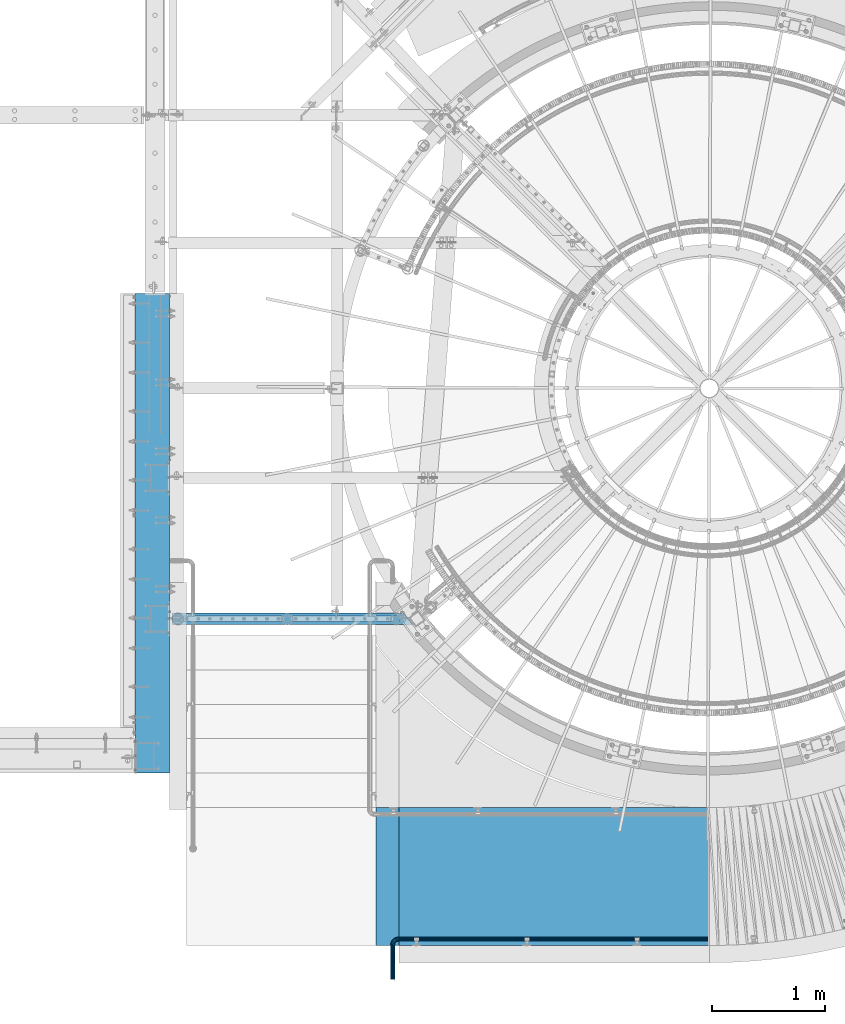
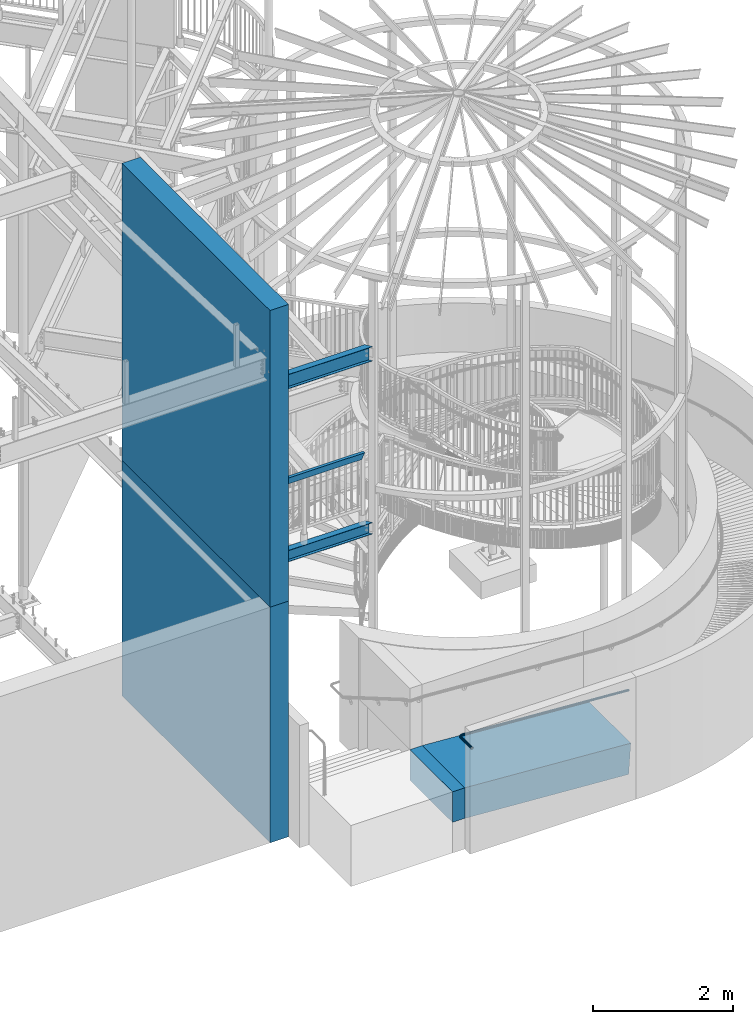
# One storey, part 334 of 975: 8 beams.
"""IFC2X3 building model written with IfcOpenShell, lengths in millimetres."""

from ifc_helpers import new_model, si_unit, frame, origin_with_axes, place, context, subcontext, project, spatial, faceted_brep, material, type_object, element, save


model = new_model("IFC2X3")

# Units and contexts
model_context = context("Model", 3, precision=1e-05, world=origin_with_axes())
body_context = subcontext(model_context, "Body", "Model", "MODEL_VIEW")
ifc_project = project(units=[si_unit("LENGTHUNIT", "METRE", prefix="MILLI"), si_unit("AREAUNIT", "SQUARE_METRE"), si_unit("VOLUMEUNIT", "CUBIC_METRE"), si_unit("MASSUNIT", "GRAM", prefix="KILO"), si_unit("TIMEUNIT", "SECOND"), si_unit("PLANEANGLEUNIT", "RADIAN"), si_unit("SOLIDANGLEUNIT", "STERADIAN"), si_unit("THERMODYNAMICTEMPERATUREUNIT", "DEGREE_CELSIUS"), si_unit("LUMINOUSINTENSITYUNIT", "LUMEN")], contexts=[model_context])

# Site, building, storey
site_placement = place(None, origin_with_axes())
site = spatial("IfcSite", under=ifc_project, at=site_placement, CompositionType="ELEMENT")
building_placement = place(site_placement, origin_with_axes())
building = spatial("IfcBuilding", under=site, at=building_placement, Name="Undefined", CompositionType="ELEMENT")
storey_placement = place(building_placement, origin_with_axes())
storey = spatial("IfcBuildingStorey", under=building, at=storey_placement, Name="Undefined", CompositionType="ELEMENT", Elevation=0.0)

# Beams
ifc_material_1 = material()
beam_type_1 = type_object("IfcBeamType", PredefinedType="NOTDEFINED")
beam_1_placement = place(storey_placement, frame((34733.2743603004, -1466.84998513613, 1780.94769340117), z_axis=(0.0, -1.0, 0.0), x_axis=(-0.997824495007209, 0.0, 0.0659263010005001)))
element("IfcBeam", 1, at=beam_1_placement, inside=storey, type_object=beam_type_1, material=ifc_material_1, Name="HANDRAIL", context=body_context, shape_type="Brep", body=[
    faceted_brep([(-2.63386027654633e-07, -19.0500000000029, 0.0), (-2.28097633225843e-07, -16.4977839420972, -9.52499999999964), (2747.42550358236, -16.4977819359397, -9.52499981342589), (2747.42550358358, -19.0499979938454, 1.86573970495374e-07), (-1.31691194837913e-07, -9.52500000000146, -16.4977839420935), (2747.42550357773, -9.52499799384577, -16.4977837555193), (-3.63797880709171e-12, 3.63797880709171e-12, -19.0500000000002), (2747.42550357094, 2.00615295398165e-06, -19.0499998134258), (1.31687556859106e-07, 9.52500000000509, -16.4977839420935), (2747.4255035638, 9.52500200615304, -16.4977837555193), (2.28097633225843e-07, 16.4977839421044, -9.52499999999964), (2747.42550355823, 16.4977859482465, -9.52499981342589), (2.63382389675826e-07, 19.0500000000138, 0.0), (2747.42550355572, 19.0500020061527, 1.86574197869049e-07), (2.28097633225843e-07, 16.4977839421044, 9.52499999999964), (2747.42550355694, 16.4977859482465, 9.52500018657452), (1.31687556859106e-07, 9.52500000000509, 16.4977839420935), (2747.42550356158, 9.5250020061535, 16.4977841286679), (-3.63797880709171e-12, 3.63797880709171e-12, 19.0500000000002), (2747.42550356837, 2.00615386347636e-06, 19.0500001865744), (-1.31691194837913e-07, -9.52500000000146, 16.4977839420935), (2747.4255035755, -9.52499799384623, 16.4977841286677), (-2.28097633225843e-07, -16.4977839420972, 9.52499999999964), (2747.42550358107, -16.4977819359397, 9.52500018657406), (-2.1246523829177e-07, -15.367000000002, 0.0), (-1.83998054126278e-07, -13.3082123799541, 7.68350000000009), (2747.42550357886, -13.3082103738016, 7.68350018657429), (2747.42550358089, -15.3669979938459, 1.86574425242725e-07), (-1.06232619145885e-07, -7.68349999999919, 13.3082123799559), (2747.42550357437, -7.68349799384578, 13.3082125665296), (-3.63797880709171e-12, 3.63797880709171e-12, 15.3670000000002), (2747.42550356861, 2.00615386347636e-06, 15.3670001865744), (1.06225343188271e-07, 7.68350000000646, 13.3082123799559), (2747.42550356313, 7.6835020061535, 13.3082125665296), (1.8399441614747e-07, 13.308212379965, 7.68350000000009), (2747.4255035594, 13.3082143861088, 7.68350018657429), (2.12461600312963e-07, 15.3670000000093, 0.0), (2747.42550355841, 15.3670020061527, 1.86574425242725e-07), (1.8399441614747e-07, 13.308212379965, -7.68350000000009), (2747.42550356044, 13.3082143861079, -7.6834998134259), (1.06225343188271e-07, 7.68350000000646, -13.3082123799559), (2747.42550356493, 7.68350200615305, -13.3082121933812), (-3.63797880709171e-12, 3.63797880709171e-12, -15.3670000000002), (2747.42550357069, 2.00615340872901e-06, -15.3669998134258), (-1.06232619145885e-07, -7.68349999999919, -13.3082123799559), (2747.42550357617, -7.68349799384623, -13.3082121933815), (-1.83998054126278e-07, -13.3082123799541, -7.68350000000009), (2747.4255035799, -13.308210373802, -7.68349981342567), (2749.09855348467, -16.4977819347173, -9.52499981331198), (2749.18278450733, -19.0499979925621, 1.86693569048657e-07), (2748.86844838869, -9.52499799279258, -16.4977837554213), (2748.55412569402, 2.00697741092881e-06, -19.0499998133491), (2748.23980791288, 9.5250020067474, -16.4977837554641), (2748.00971624088, 16.497785948673, -9.5249998133861), (2747.92550355573, 19.0500020065178, 1.86608303920366e-07), (2748.00973457838, 16.497785948673, 9.52500018661385), (2748.23983967437, 9.52500200674785, 16.4977841287232), (2748.55416236903, 2.00697786567616e-06, 19.050000186651), (2748.86848015017, -9.52499799279258, 16.4977841287659), (2749.09857182217, -16.4977819347178, 9.52500018668798), (2748.99331578265, -13.3082103726565, 7.6835001866807), (2749.06124734867, -15.3669979926512, 1.86685383596341e-07), (2748.80770850056, -7.68349799283669, 13.3082125666238), (2748.55415882378, 2.00697832042351e-06, 15.3670001866508), (2748.30060518342, 7.68350200679242, 13.3082125665892), (2748.11498707266, 13.3082143866118, 7.6835001866209), (2748.04704071438, 15.367002006607, 1.86616489372682e-07), (2748.11497228041, 13.3082143866118, -7.68349981337883), (2748.30057956249, 7.68350200679151, -13.3082121933219), (2748.55412923927, 2.00697741092881e-06, -15.3669998133491), (2748.80768287963, -7.68349799283669, -13.3082121932873), (2748.99330099039, -13.308210372657, -7.68349981331926), (2750.76796359829, -16.387483031016, -9.52500198382563), (2750.93624235249, -18.9341453696939, -1.98383168026339e-06), (2750.30825404867, -9.42986971660639, -16.4977859259375), (2749.68029250621, 0.0744077046915663, -19.0500019838819), (2749.05234075907, 9.57868577320005, -16.4977859260225), (2748.59265797081, 16.5363008558202, -9.5250019839732), (2748.4244157733, 19.082965609919, -1.98400221051998e-06), (2748.5926945275, 16.5363032712407, 9.52499801599151), (2749.05240407712, 9.57868995683066, 16.4977819581034), (2749.68036561958, 0.0744125355327014, 19.0499980160475), (2750.30831736671, -9.42986553297533, 16.4977819581886), (2750.76800015497, -16.3874806155959, 9.52499801613908), (2750.55771707717, -13.2048484066922, 7.68349801612817), (2750.69343244983, -15.2591579749978, -1.9838482785417e-06), (2750.18690629464, -7.59237224004482, 13.3082103960483), (2749.68035855196, 0.0744120685517373, 15.3669980160544), (2749.1738029077, 7.7411958550656, 13.3082103959794), (2748.80297053767, 13.3536705953561, 7.68349801600925), (2748.66722567595, 15.4079782152226, -1.98398583961534e-06), (2748.80294104861, 13.3536686469165, -7.68350198396251), (2749.17375183115, 7.74119248026955, -13.3082143638824), (2749.68029957383, 0.0744081716734399, -15.3670019838887), (2750.18685521809, -7.59237561484088, -13.3082143638137), (2750.55768758811, -13.2048503551318, -7.68350198384337), (2755.38214503701, -16.082619687113, -9.52501087703058), (2755.55042379118, -18.6292820257891, -2.03573856651929e-05), (2754.92243548739, -9.12500637270387, -16.4977948191422), (2754.29447394492, 0.379271048594546, -19.0500108770866), (2753.66652219779, 9.88354911710258, -16.4977948192275), (2753.20683940953, 16.8411641997232, -9.52501087717792), (2753.03859721201, 19.387828953822, -1.08772071598651e-05), (2753.20687596621, 16.8411666151437, 9.52498912278679), (2753.66658551584, 9.88355330073364, 16.4977730648986), (2754.2945470583, 0.379275879435681, 19.0499891228428), (2754.92249880543, -9.12500218907235, 16.4977730649837), (2755.38218159369, -16.0826172716929, 9.52498912293413), (2755.17189851589, -12.8999850627897, 7.68348912292322), (2755.30761388853, -14.9542946310944, -1.85245348802709e-05), (2754.80108773335, -7.28750889614184, 13.3082015028433), (2754.29453999067, 0.379275412454717, 15.3669891228496), (2753.78798434642, 8.04605919896858, 13.3082015027744), (2753.41715197639, 13.6585339392586, 7.6834891228043), (2753.28140711467, 15.7128415591255, -1.08771905615868e-05), (2753.41712248732, 13.6585319908195, -7.68351087716724), (2753.78793326986, 8.04605582417253, -13.3082232570873), (2754.29448101255, 0.379271515575965, -15.3670108770934), (2754.80103665681, -7.2875122709379, -13.3082232570184), (2755.17186902683, -12.8999870112289, -7.68351087704832), (2771.21427477107, -17.5943535416877, 2.48625571275124), (2768.10906131745, -15.2417425758399, 11.5450802974888), (2765.49936367507, -8.42618490231234, 18.1766022661197), (2764.08444821971, 1.0260963043047, 20.6039106625612), (2764.24344040497, 10.5823699280672, 18.1766101622038), (2765.93373840322, 17.6820401688369, 11.5450939739067), (2768.70242823086, 20.4227561190723, 2.48627150491802), (2771.80764168449, 18.0701451532241, -6.57255307981995), (2774.41733932686, 11.254587479697, -13.2040750484514), (2775.83225478223, 1.80230627307947, -15.6313834448922), (2775.67326259696, -7.75396735068307, -13.2040829445345), (2773.98296459871, -14.8536375914523, -6.57256675623785), (2774.69663348118, 1.72727264276409, -12.1286383478387), (2773.55526834719, 9.35211281610236, -10.1706095747093), (2771.450112249, 14.8499960060813, -4.82118185334707), (2768.94524006308, 16.7477688518652, 2.48626997834185), (2766.71183026878, 14.536924652009, 9.793720103326), (2765.34832321686, 8.8098573244547, 15.1431431618855), (2765.22006952075, 1.10112993461962, 17.101165565507), (2766.36143465474, -6.52371023871865, 15.1431367923781), (2768.46659075292, -12.0215934286975, 9.79370907101543), (2770.97146293885, -13.9193662744806, 2.48625723932696), (2773.20487273314, -11.7085220746244, -4.82119288565696), (2774.56837978507, -5.98145474707007, -10.1706159442167), (2788.58769674432, 19.1788296229693, 1.99586386588931), (2793.13695432239, 12.4914217064702, -3.64525859803371), (2782.83299844192, 21.3563849829693, 9.70177925010557), (2777.414826178, 18.4406135862837, 17.4076937504717), (2773.78497483513, 11.2127940239689, 23.0488137996706), (2772.91606014927, 1.60961471078417, 25.1136058361128), (2775.04090710881, -7.79576021153025, 23.0488105010952), (2779.59016468688, -14.4831681280298, 17.4076880371726), (2785.34486298928, -16.6607234880294, 9.70177265295683), (2790.7630352532, -13.7449520913437, 1.99585815259093), (2794.39288659607, -6.51713252902891, -3.64526189660751), (2795.26180128193, 3.08604678415531, -5.71005393305086), (2792.40078845918, -4.80323962890498, -1.06483457930085), (2793.10171297244, 2.94332501706276, -2.73043348869805), (2789.47270837593, -10.6336807425068, 3.48566892705276), (2785.10204941637, -12.9857363358328, 9.7017732906811), (2780.4599261191, -11.2291750120999, 15.9178783672814), (2776.79019167279, -5.83466595945765, 20.4683838215128), (2775.07614845876, 1.75233647787672, 22.1339853917602), (2775.77707297202, 9.49890112384537, 20.4683864823635), (2778.70515305526, 15.3293422374468, 15.9178829760097), (2783.07581201483, 17.6813978307728, 9.70177861238108), (2787.7179353121, 15.9248365070393, 3.48567353578005), (2791.38766975841, 10.5303274543971, -1.06483191845155), (2801.90447160004, 20.0586976371446, 15.3415200033737), (2807.99297817883, 13.4729912194134, 11.2429848472711), (2794.04712267527, 22.0973263390279, 20.9402245585879), (2786.52630170356, 19.0426284107257, 26.5389301486844), (2781.35720659071, 11.7131076952487, 30.6374681321361), (2779.92489219779, 2.07270334921532, 32.1376385661292), (2782.61314600969, -7.29544606814443, 30.6374719943667), (2788.70165258848, -13.8811524858756, 26.5389368382646), (2796.55900151325, -15.9197811877589, 20.9402322830508), (2804.07982248496, -12.8650832594572, 15.3415266929551), (2809.24891759782, -5.53556254397927, 11.2429887095032), (2810.68123199074, 4.10484180205322, 9.74281827550976), (2806.55271886713, -3.8681910875207, 13.1177883870243), (2807.70811914409, 3.90840175161293, 11.9076509036022), (2802.38298214276, -9.78067113133966, 16.4239423603419), (2796.31618655891, -12.244794126836, 20.9402315363525), (2789.97792509294, -10.600300307317, 25.4565198775583), (2785.06652978605, -5.28783046368108, 28.7626715701474), (2782.89800504444, 2.26914339965651, 29.9728059380359), (2784.0534053214, 10.0457362387901, 28.7626684546144), (2788.22314204577, 15.9582162826082, 25.4565144812966), (2794.28993762961, 18.4223392781055, 20.9402253052856), (2800.62819909559, 16.7778454585855, 16.4239369640798), (2805.53959440248, 11.4653756149496, 13.1177852714911), (2810.4544402639, 20.6236224244649, 32.1580622713866), (2817.53121396176, 14.1032140930779, 30.0033045059822), (2801.24709502793, 22.5730523925317, 35.1015208343117), (2792.37627897428, 19.4291558116342, 38.0449828498672), (2786.2189201007, 12.0343372317107, 40.1997500480331), (2784.42487774491, 2.37003231942572, 40.9884542981831), (2787.4748641073, -6.97421622856427, 40.1997629334228), (2794.55163780516, -13.4946245599508, 38.0450051680186), (2803.75898304113, -15.4440545280181, 35.1015466050942), (2812.62979909479, -12.3001579471206, 32.1580845895392), (2818.78715796836, -4.90533936719658, 30.0033173913744), (2820.58120032416, 4.75896554508699, 29.2146131412228), (2815.63889497448, -3.26783729596946, 30.9889725481842), (2817.0860891415, 4.52803533327324, 30.3527511197287), (2810.67195881647, -9.23299095044058, 32.7271514213708), (2803.51616719986, -11.7690675256986, 35.1015441139186), (2796.08890870951, -10.1965273514575, 37.4759340213441), (2790.3803112599, -4.93673129747231, 39.2141052854372), (2787.91998892757, 2.60096253124038, 39.8503163196765), (2789.36718309458, 10.3968351604826, 39.214094891222), (2794.33411925259, 16.3619888149547, 37.4759160180352), (2801.48991086921, 18.8980653902122, 35.1015233254871), (2808.91716935955, 17.3255252159715, 32.7271334180609), (2814.62576680916, 12.0657291619859, 30.9889621539678), (2822.07394739316, -4.6881530323335, 50.7993503842929), (2815.57604196683, -12.1054744404232, 50.7994260486921), (2823.99263785981, 4.98438844848124, 50.7993143117353), (2820.81800180572, 14.320400323481, 50.7993274966309), (2813.40068039783, 20.8183057502315, 50.7993864060984), (2803.7281389174, 22.736996217142, 50.7994752553939), (2794.39212704287, 19.5623601630778, 50.7995702374192), (2787.89422161653, 12.145038754988, 50.7996459018182), (2785.97553114988, 2.47249727417284, 50.7996819743757), (2789.15016720398, -6.86351460082687, 50.7996687894797), (2796.56748861186, -13.3614200275774, 50.7996098800118), (2806.24002063258, -15.2801111195172, 50.7995210308095), (2818.76990723475, -3.06094449289276, 50.7993789509869), (2820.31765087785, 4.741572301632, 50.7993498524572), (2813.52826352418, -9.04425042875164, 50.7994399869353), (2805.99720631455, -11.6051240165548, 50.799516605844), (2798.19469715118, -10.0573798690552, 50.7995882775338), (2792.21139121548, -4.81573615814341, 50.7996357978379), (2789.65051813184, 2.71531342102253, 50.7996464336541), (2791.19826177494, 10.5178302155468, 50.7996173351239), (2796.43990548552, 16.5011361514057, 50.7995562991757), (2803.97095506431, 19.0620092350173, 50.7994796803416), (2811.77347185852, 17.5142655917102, 50.7994080085768), (2817.75677779422, 12.2726218807979, 50.7993604882731), (2815.57894484306, -12.1049203894595, 355.599163614369), (2806.24293138865, -15.2795517974005, 355.599258596402), (2822.07685396067, -4.68760221509319, 355.59908794994), (2823.99554924092, 4.98493831087262, 355.599051877338), (2820.82091783294, 14.3209517657483, 355.599065062187), (2813.40359965877, 20.8188608837731, 355.599123971618), (2803.73105913319, 22.7375561642825, 355.599212820897), (2794.39504567878, 19.5629247563415, 355.59930780293), (2787.89713656117, 12.1456065819748, 355.599383467359), (2785.97844128092, 2.47306605600852, 355.599419539961), (2789.1530726889, -6.86294739886671, 355.599406355112), (2796.57039086307, -13.3608565168911, 355.599347445681), (2798.19760104665, -10.0568171681603, 355.599325843188), (2806.00011707062, -11.6045646944376, 355.599254171437), (2792.21429771949, -4.81517047962052, 355.599373363463), (2789.65342838372, 2.71588037397896, 355.599383999241), (2791.20117590979, 10.5183963982586, 355.599354900675), (2796.44282259799, 16.5016997255811, 355.599293864703), (2803.97387345122, 19.0625690613192, 355.599217245863), (2811.77638947519, 17.5148215350423, 355.599145574111), (2817.75969280235, 12.2731748465026, 355.599098053837), (2820.32056213811, 4.74212399290309, 355.599087418058), (2818.77281461205, -3.06039203137652, 355.599116516624), (2813.53116792384, -9.0436953586991, 355.599177552596)], [[[0, 1, 2, 3]], [[1, 4, 5, 2]], [[4, 6, 7, 5]], [[6, 8, 9, 7]], [[8, 10, 11, 9]], [[10, 12, 13, 11]], [[12, 14, 15, 13]], [[14, 16, 17, 15]], [[16, 18, 19, 17]], [[18, 20, 21, 19]], [[20, 22, 23, 21]], [[22, 0, 3, 23]], [[24, 25, 26, 27]], [[25, 28, 29, 26]], [[28, 30, 31, 29]], [[30, 32, 33, 31]], [[32, 34, 35, 33]], [[34, 36, 37, 35]], [[36, 38, 39, 37]], [[38, 40, 41, 39]], [[40, 42, 43, 41]], [[42, 44, 45, 43]], [[44, 46, 47, 45]], [[46, 24, 27, 47]], [[22, 20, 18, 16, 14, 12, 10, 8, 6, 4, 1, 0], [46, 44, 42, 40, 38, 36, 34, 32, 30, 28, 25, 24]], [[3, 2, 48, 49]], [[2, 5, 50, 48]], [[5, 7, 51, 50]], [[7, 9, 52, 51]], [[9, 11, 53, 52]], [[11, 13, 54, 53]], [[13, 15, 55, 54]], [[15, 17, 56, 55]], [[17, 19, 57, 56]], [[19, 21, 58, 57]], [[21, 23, 59, 58]], [[23, 3, 49, 59]], [[27, 26, 60, 61]], [[26, 29, 62, 60]], [[29, 31, 63, 62]], [[31, 33, 64, 63]], [[33, 35, 65, 64]], [[35, 37, 66, 65]], [[37, 39, 67, 66]], [[39, 41, 68, 67]], [[41, 43, 69, 68]], [[43, 45, 70, 69]], [[45, 47, 71, 70]], [[47, 27, 61, 71]], [[49, 48, 72, 73]], [[48, 50, 74, 72]], [[50, 51, 75, 74]], [[51, 52, 76, 75]], [[52, 53, 77, 76]], [[53, 54, 78, 77]], [[54, 55, 79, 78]], [[55, 56, 80, 79]], [[56, 57, 81, 80]], [[57, 58, 82, 81]], [[58, 59, 83, 82]], [[59, 49, 73, 83]], [[61, 60, 84, 85]], [[60, 62, 86, 84]], [[62, 63, 87, 86]], [[63, 64, 88, 87]], [[64, 65, 89, 88]], [[65, 66, 90, 89]], [[66, 67, 91, 90]], [[67, 68, 92, 91]], [[68, 69, 93, 92]], [[69, 70, 94, 93]], [[70, 71, 95, 94]], [[71, 61, 85, 95]], [[73, 72, 96, 97]], [[72, 74, 98, 96]], [[74, 75, 99, 98]], [[75, 76, 100, 99]], [[76, 77, 101, 100]], [[77, 78, 102, 101]], [[78, 79, 103, 102]], [[79, 80, 104, 103]], [[80, 81, 105, 104]], [[81, 82, 106, 105]], [[82, 83, 107, 106]], [[83, 73, 97, 107]], [[85, 84, 108, 109]], [[84, 86, 110, 108]], [[86, 87, 111, 110]], [[87, 88, 112, 111]], [[88, 89, 113, 112]], [[89, 90, 114, 113]], [[90, 91, 115, 114]], [[91, 92, 116, 115]], [[92, 93, 117, 116]], [[93, 94, 118, 117]], [[94, 95, 119, 118]], [[95, 85, 109, 119]], [[107, 97, 120, 121]], [[106, 107, 121, 122]], [[105, 106, 122, 123]], [[104, 105, 123, 124]], [[103, 104, 124, 125]], [[102, 103, 125, 126]], [[101, 102, 126, 127]], [[100, 101, 127, 128]], [[99, 100, 128, 129]], [[98, 99, 129, 130]], [[96, 98, 130, 131]], [[97, 96, 131, 120]], [[116, 117, 132, 133]], [[115, 116, 133, 134]], [[114, 115, 134, 135]], [[113, 114, 135, 136]], [[112, 113, 136, 137]], [[111, 112, 137, 138]], [[110, 111, 138, 139]], [[108, 110, 139, 140]], [[109, 108, 140, 141]], [[119, 109, 141, 142]], [[118, 119, 142, 143]], [[117, 118, 143, 132]], [[127, 144, 145, 128]], [[126, 146, 144, 127]], [[125, 147, 146, 126]], [[124, 148, 147, 125]], [[123, 149, 148, 124]], [[122, 150, 149, 123]], [[121, 151, 150, 122]], [[120, 152, 151, 121]], [[131, 153, 152, 120]], [[130, 154, 153, 131]], [[129, 155, 154, 130]], [[128, 145, 155, 129]], [[143, 156, 157, 132]], [[142, 158, 156, 143]], [[141, 159, 158, 142]], [[140, 160, 159, 141]], [[139, 161, 160, 140]], [[138, 162, 161, 139]], [[137, 163, 162, 138]], [[136, 164, 163, 137]], [[135, 165, 164, 136]], [[134, 166, 165, 135]], [[133, 167, 166, 134]], [[132, 157, 167, 133]], [[144, 168, 169, 145]], [[146, 170, 168, 144]], [[147, 171, 170, 146]], [[148, 172, 171, 147]], [[149, 173, 172, 148]], [[150, 174, 173, 149]], [[151, 175, 174, 150]], [[152, 176, 175, 151]], [[153, 177, 176, 152]], [[154, 178, 177, 153]], [[155, 179, 178, 154]], [[145, 169, 179, 155]], [[156, 180, 181, 157]], [[158, 182, 180, 156]], [[159, 183, 182, 158]], [[160, 184, 183, 159]], [[161, 185, 184, 160]], [[162, 186, 185, 161]], [[163, 187, 186, 162]], [[164, 188, 187, 163]], [[165, 189, 188, 164]], [[166, 190, 189, 165]], [[167, 191, 190, 166]], [[157, 181, 191, 167]], [[168, 192, 193, 169]], [[170, 194, 192, 168]], [[171, 195, 194, 170]], [[172, 196, 195, 171]], [[173, 197, 196, 172]], [[174, 198, 197, 173]], [[175, 199, 198, 174]], [[176, 200, 199, 175]], [[177, 201, 200, 176]], [[178, 202, 201, 177]], [[179, 203, 202, 178]], [[169, 193, 203, 179]], [[180, 204, 205, 181]], [[182, 206, 204, 180]], [[183, 207, 206, 182]], [[184, 208, 207, 183]], [[185, 209, 208, 184]], [[186, 210, 209, 185]], [[187, 211, 210, 186]], [[188, 212, 211, 187]], [[189, 213, 212, 188]], [[190, 214, 213, 189]], [[191, 215, 214, 190]], [[181, 205, 215, 191]], [[202, 216, 217, 201]], [[203, 218, 216, 202]], [[193, 219, 218, 203]], [[192, 220, 219, 193]], [[194, 221, 220, 192]], [[195, 222, 221, 194]], [[196, 223, 222, 195]], [[197, 224, 223, 196]], [[198, 225, 224, 197]], [[199, 226, 225, 198]], [[200, 227, 226, 199]], [[201, 217, 227, 200]], [[204, 228, 229, 205]], [[206, 230, 228, 204]], [[207, 231, 230, 206]], [[208, 232, 231, 207]], [[209, 233, 232, 208]], [[210, 234, 233, 209]], [[211, 235, 234, 210]], [[212, 236, 235, 211]], [[213, 237, 236, 212]], [[214, 238, 237, 213]], [[215, 239, 238, 214]], [[205, 229, 239, 215]], [[227, 217, 240, 241]], [[217, 216, 242, 240]], [[216, 218, 243, 242]], [[218, 219, 244, 243]], [[219, 220, 245, 244]], [[220, 221, 246, 245]], [[221, 222, 247, 246]], [[222, 223, 248, 247]], [[223, 224, 249, 248]], [[224, 225, 250, 249]], [[225, 226, 251, 250]], [[226, 227, 241, 251]], [[231, 232, 252, 253]], [[232, 233, 254, 252]], [[233, 234, 255, 254]], [[234, 235, 256, 255]], [[235, 236, 257, 256]], [[236, 237, 258, 257]], [[237, 238, 259, 258]], [[238, 239, 260, 259]], [[239, 229, 261, 260]], [[229, 228, 262, 261]], [[228, 230, 263, 262]], [[230, 231, 253, 263]], [[242, 243, 244, 245, 246, 247, 248, 249, 250, 251, 241, 240], [254, 255, 256, 257, 258, 259, 260, 261, 262, 263, 253, 252]]]),
])
ifc_material_2 = material(Name="STEEL/Zero_Density")
beam_type_2 = type_object("IfcBeamType", PredefinedType="NOTDEFINED")
beam_2_placement = place(storey_placement, frame((31991.2996198831, -914.399982957186, 800.100000577925), z_axis=(0.0, -1.0, 0.0), x_axis=(-0.999999999999998, 6.90000001668524e-08, 0.0)))
element("IfcBeam", 2, at=beam_2_placement, inside=storey, type_object=beam_type_2, material=ifc_material_2, Name="SLAB", context=body_context, shape_type="Brep", body=[
    faceted_brep([(8.29459168016911e-10, 266.699999999988, -609.599999999988), (-1.25874066725373e-09, 266.699999999988, 609.599999999969), (203.230320247581, 266.699999999986, 609.599999999971), (203.230320249673, 266.699999999986, -609.599999999986), (-8.36735125631094e-10, -266.699999999988, 609.599999999988), (203.230320248003, -266.699999999991, 609.59999999999), (1.25146470963955e-09, -266.699999999988, -609.599999999969), (203.230320250092, -266.699999999991, -609.599999999968)], [[[0, 1, 2, 3]], [[1, 4, 5, 2]], [[4, 6, 7, 5]], [[6, 0, 3, 7]], [[5, 7, 3, 2]], [[6, 4, 1, 0]]]),
])
beam_type_3 = type_object("IfcBeamType", Name="HSS2X4X.188_TUBES", PredefinedType="NOTDEFINED")
beam_3_placement = place(storey_placement, frame((30035.4999964607, 1364.99484496256, 5130.79999704288), z_axis=(0.0, 0.0, 1.0), x_axis=(0.999999998764607, -4.97069999879304e-05, -1.40000005822416e-08)))
element("IfcBeam", 3, at=beam_3_placement, inside=storey, type_object=beam_type_3, material=ifc_material_1, Name="GUARDRAIL", ObjectType="HSS2X4X.188_TUBES", context=body_context, shape_type="Brep", body=[
    faceted_brep([(23.0198915490837, 20.6374999999994, -46.0375000000031), (23.0198915283145, -20.6374999999966, -46.0375000000085), (1908.94073557058, -20.637499999908, -46.0375000005661), (1908.9407355706, 20.6375000000878, -46.0375000005615), (-23.0198845522937, -20.6374999999985, 46.0375000000058), (1954.98050102809, -20.6374999999057, 46.0374999994201), (-23.0198845315244, 20.6374999999973, 46.0375000000113), (1954.9805010281, 20.6375000000903, 46.0374999994256), (25.4012592797953, 25.399999999999, -50.8000000000029), (-25.4012522574303, 25.3999999999967, 50.800000000012), (1957.36186820694, 25.4000000000897, 50.7999999994254), (1906.55936839176, 25.4000000000874, -50.8000000005595), (-25.401252282998, -25.3999999999983, 50.8000000000056), (1957.36186820692, -25.399999999905, 50.799999999419), (25.401259254224, -25.399999999996, -50.8000000000102), (1906.55936839174, -25.3999999999075, -50.8000000005668)], [[[0, 1, 2, 3]], [[1, 4, 5, 2]], [[4, 6, 7, 5]], [[6, 0, 3, 7]], [[8, 9, 10, 11]], [[9, 12, 13, 10]], [[12, 14, 15, 13]], [[14, 8, 11, 15]], [[13, 15, 11, 10], [5, 7, 3, 2]], [[14, 12, 9, 8], [6, 4, 1, 0]]]),
])
beam_type_4 = type_object("IfcBeamType", PredefinedType="NOTDEFINED")
beam_4_placement = place(storey_placement, frame((34716.7846204266, -913.670093792204, 619.436446979233), z_axis=(0.000267793573642848, -0.9999999641433, -3.78978484150139e-11), x_axis=(-0.997824497086137, -0.000267211000023054, 0.065925728005691)))
element("IfcBeam", 4, at=beam_4_placement, inside=storey, type_object=beam_type_4, material=ifc_material_2, Name="SLAB", context=body_context, shape_type="Brep", body=[
    faceted_brep([(1.25146470963955e-09, -266.699999999988, -609.599999999969), (-8.36735125631094e-10, -266.699999999988, 609.599999999988), (-1.25874066725373e-09, 266.699999999988, 609.599999999969), (8.29459168016911e-10, 266.699999999988, -609.599999999988), (2749.2112133443, -266.700000000517, 609.600000000071), (2713.96976288369, 266.699999999445, 609.600000000064), (2713.969763409, 266.699999999782, -609.599999999919), (2749.21121334864, -266.700000000181, -609.599999999912)], [[[0, 1, 2, 3]], [[2, 1, 4, 5]], [[3, 2, 5, 6]], [[0, 3, 6, 7]], [[1, 0, 7, 4]], [[6, 5, 4, 7]]]),
])
ifc_material_3 = material(Name="STEEL/A992")
beam_type_5 = type_object("IfcBeamType", Name="W8X10", PredefinedType="NOTDEFINED")
beam_5_placement = place(storey_placement, frame((29959.3, 1364.99507678835, 3836.9875), z_axis=(0.0, 0.0, 1.0), x_axis=(1.0, 0.0, 0.0)))
element("IfcBeam", 5, at=beam_5_placement, inside=storey, type_object=beam_type_5, material=ifc_material_3, Name="BEAM", ObjectType="W8X10", context=body_context, shape_type="Brep", body=[
    faceted_brep([(25.3999999993466, -50.7999999999975, -95.25), (25.3999999993466, -50.7999999999975, -100.0125), (2149.34801391398, -50.7999999997951, -100.0125), (2149.34801391398, -50.7999999997951, -95.25), (25.3999999993721, -2.38124999999741, -95.25), (2114.43300614579, -2.38124999979868, -95.25), (25.3999999993721, -2.38124999999741, 95.25), (2114.43300614579, -2.38124999979868, 95.25), (25.3999999993466, -50.7999999999975, 95.25), (2149.34801391398, -50.7999999997951, 95.25), (25.3999999993466, -50.7999999999975, 100.0125), (2149.34801391398, -50.7999999997951, 100.0125), (25.3999999993976, 50.8000000000025, 100.0125), (2076.08373531845, 50.800000000198, 100.0125), (25.3999999993976, 50.8000000000025, 95.25), (2076.08373531845, 50.800000000198, 95.25), (25.3999999993721, 2.38125000000264, 95.25), (2110.99874308663, 2.38125000020113, 95.25), (25.3999999993721, 2.38125000000264, -95.25), (2110.99874308663, 2.38125000020113, -95.25), (25.3999999993976, 50.8000000000025, -95.25), (2076.08373531845, 50.800000000198, -95.25), (25.3999999993976, 50.8000000000025, -100.0125), (2076.08373531845, 50.800000000198, -100.0125)], [[[0, 1, 2, 3]], [[4, 0, 3, 5]], [[6, 4, 5, 7]], [[8, 6, 7, 9]], [[10, 8, 9, 11]], [[12, 10, 11, 13]], [[14, 12, 13, 15]], [[16, 14, 15, 17]], [[18, 16, 17, 19]], [[20, 18, 19, 21]], [[1, 0, 4, 6, 8, 10, 12, 14, 16, 18, 20, 22]], [[1, 22, 23, 2]], [[19, 17, 15, 13, 11, 9, 7, 5, 3, 2, 23, 21]], [[22, 20, 21, 23]]]),
])
beam_type_6 = type_object("IfcBeamType", Name="W10X12", PredefinedType="NOTDEFINED")
beam_6_placement = place(storey_placement, frame((29959.2998463017, 1365.00777101716, 6884.9875), z_axis=(0.0, 0.0, 1.0), x_axis=(1.0, 0.0, 0.0)))
element("IfcBeam", 6, at=beam_6_placement, inside=storey, type_object=beam_type_6, material=ifc_material_3, Name="BEAM", ObjectType="W10X12", context=body_context, shape_type="Brep", body=[
    faceted_brep([(31.7499968046977, -2.38124999999945, -100.012499999501), (31.7499973333288, 2.38125000000059, -100.012499999501), (107.950002874364, 2.37408225313834, -100.012499999431), (107.950002874379, -2.38124999999854, -100.012499999431), (112.810082392418, 2.37404298604497, -100.979229922017), (112.810082392429, -2.38124999999854, -100.979229922017), (116.930258860575, 2.37393154096867, -103.732243822496), (116.93025886059, -2.38124999999854, -103.732243822496), (119.683272761056, 2.37376488441146, -107.852420290656), (119.683272761071, -2.38124999999854, -107.852420290656), (120.650002683655, -2.38124999999854, -112.712499808707), (120.65000268364, 2.37356838832375, -112.712499808707), (120.650002683484, 2.36197772804576, -120.65), (120.650002683484, 50.8000000000015, -120.65), (120.65000268348, 50.8000000000015, -125.4125), (120.65000268348, -50.7999999999988, -125.4125), (120.650002683484, -50.7999999999988, -120.65), (120.650002683484, -2.38124999999854, -120.65), (2149.77878176484, -50.7999999999774, 120.65), (2149.77878176484, -50.7999999999774, 125.4125), (120.65000268356, -50.7999999999988, 125.4125), (120.650002683557, -50.7999999999988, 120.65), (2076.52933473248, 50.8000000000225, 125.4125), (120.65000268356, 50.8000000000015, 125.4125), (2076.52933473248, 50.8000000000225, 120.65), (120.650002683557, 50.8000000000015, 120.65), (2111.43727433384, 2.38125000002242, 120.65), (120.650002683557, 2.38125000000173, 120.65), (107.950002874448, -2.38124999999854, 100.01250000058), (107.950002874437, 2.38210065843168, 100.01250000058), (31.7499973333288, 2.38125000000059, 100.01250000058), (31.7499968046977, -2.38124999999945, 100.01250000058), (112.810082392491, -2.38124999999854, 100.979229923167), (112.81008239248, 2.38213946671999, 100.979229923167), (116.930258860644, -2.38124999999854, 103.732243823642), (116.93025886063, 2.38225023560312, 103.732243823642), (119.683272761122, -2.38124999999854, 107.852420291792), (119.683272761107, 2.38241610152318, 107.852420291792), (120.650002683713, -2.38124999999854, 112.712499809833), (120.650002683702, 2.38261181289727, 112.712499809833), (120.650002683557, -2.38124999999854, 120.65), (2114.87084216348, -2.3812499999774, 120.65), (2111.43727433384, 2.38125000002242, -120.65), (2114.87084216348, -2.3812499999774, -120.65), (2149.77878176484, -50.7999999999774, -120.65), (2149.77878176484, -50.7999999999774, -125.4125), (2076.52933473248, 50.8000000000225, -125.4125), (2076.52933473248, 50.8000000000225, -120.65)], [[[0, 1, 2, 3]], [[3, 2, 4, 5]], [[5, 4, 6, 7]], [[7, 6, 8, 9]], [[10, 11, 12, 13, 14, 15, 16, 17]], [[9, 8, 11, 10]], [[18, 19, 20, 21]], [[19, 22, 23, 20]], [[22, 24, 25, 23]], [[24, 26, 27, 25]], [[28, 29, 30, 31]], [[32, 33, 29, 28]], [[34, 35, 33, 32]], [[36, 37, 35, 34]], [[38, 39, 37, 36]], [[20, 23, 25, 27, 39, 38, 40, 21]], [[41, 18, 21, 40]], [[42, 26, 24, 22, 19, 18, 41, 43, 44, 45, 46, 47]], [[44, 43, 17, 16]], [[45, 44, 16, 15]], [[46, 45, 15, 14]], [[47, 46, 14, 13]], [[42, 47, 13, 12]], [[6, 4, 2, 1, 30, 29, 33, 35, 37, 39, 27, 26, 42, 12, 11, 8]], [[31, 30, 1, 0]], [[43, 41, 40, 38, 36, 34, 32, 28, 31, 0, 3, 5, 7, 9, 10, 17]]]),
])
ifc_material_4 = material(Name="CONCRETE/5000")
beam_type_7 = type_object("IfcBeamType", PredefinedType="NOTDEFINED")
beam_7_placement = place(storey_placement, frame((29806.8999719309, 1.50288744744162e-05, 6705.6), z_axis=(0.0, 0.0, 1.0), x_axis=(0.0, 1.0, 0.0)))
element("IfcBeam", 7, at=beam_7_placement, inside=storey, type_object=beam_type_7, material=ifc_material_4, Name="WALL", context=body_context, shape_type="Brep", body=[
    faceted_brep([(0.0, 152.400000000001, -2590.8), (0.0, 152.400000000001, 2590.8), (4241.80075319492, 152.400000005826, 2590.8), (4241.80075319492, 152.400000005826, -2590.8), (0.0, -152.400000000001, 2590.8), (4241.80075319492, -152.399999994177, 2590.8), (0.0, -152.400000000001, -2590.8), (4241.80075319492, -152.399999994177, -2590.8)], [[[0, 1, 2, 3]], [[1, 4, 5, 2]], [[4, 6, 7, 5]], [[6, 0, 3, 7]], [[5, 7, 3, 2]], [[6, 4, 1, 0]]]),
])
beam_type_8 = type_object("IfcBeamType", PredefinedType="NOTDEFINED")
beam_8_placement = place(storey_placement, frame((29806.8999719309, 1.50288744744162e-05, 2057.4), z_axis=(0.0, 0.0, 1.0), x_axis=(0.0, 1.0, 0.0)))
element("IfcBeam", 8, at=beam_8_placement, inside=storey, type_object=beam_type_8, material=ifc_material_4, Name="WALL", context=body_context, shape_type="Brep", body=[
    faceted_brep([(-4.33680868994202e-19, -152.400000000009, -2057.4), (-4.33680868994202e-19, -152.400000000009, 2057.4), (0.0, 152.399999999998, 2057.4), (0.0, 152.399999999998, -2057.4), (4241.80075319492, -152.399999994177, -2057.4), (4241.80075319492, -152.399999994177, 2057.4), (4241.80075319492, 152.400000005826, 2057.4), (4241.80075319492, 152.400000005826, -2057.4)], [[[0, 1, 2, 3]], [[1, 0, 4, 5]], [[2, 1, 5, 6]], [[3, 2, 6, 7]], [[5, 4, 7, 6]], [[0, 3, 7, 4]]]),
])

save(model, "model.ifc")
